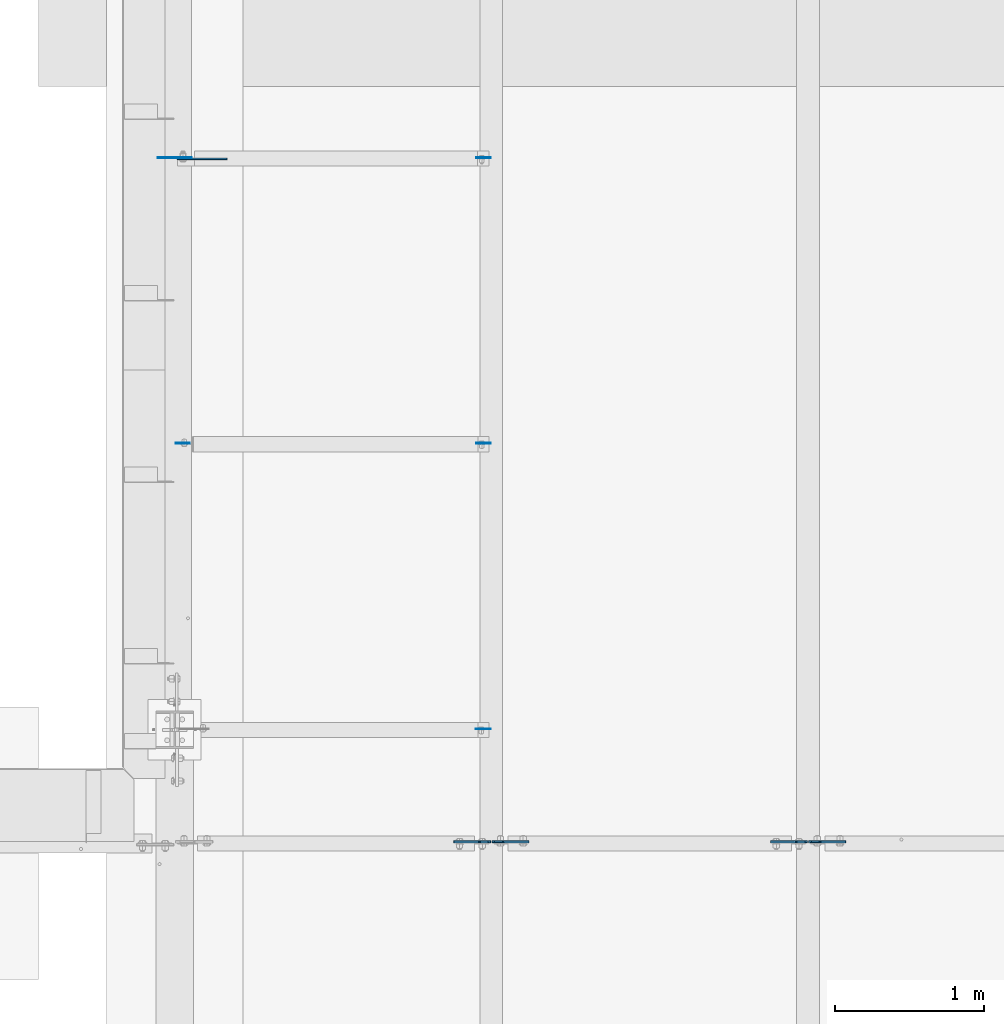
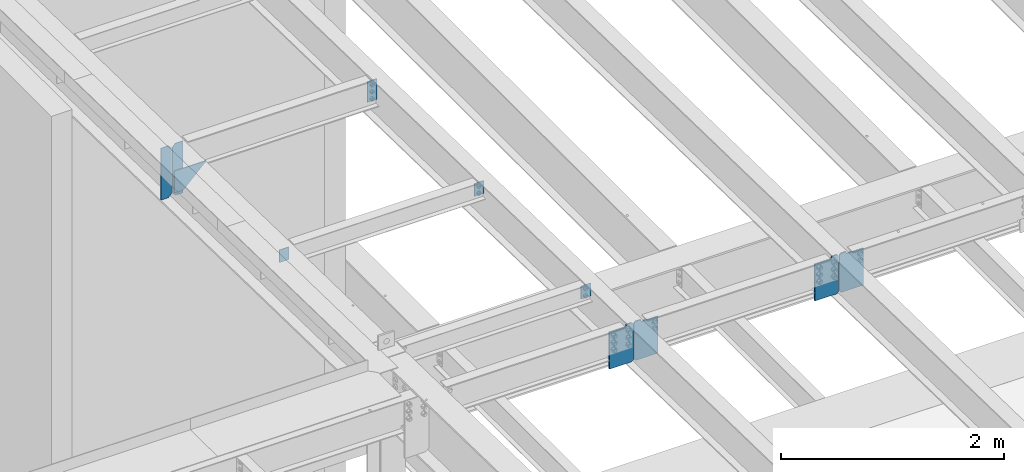
# One storey, part 1497 of 1763: 11 plates, 4 elements without a shape of their own.
"""IFC2X3 building model written with IfcOpenShell, lengths in millimetres."""

from ifc_helpers import new_model, si_unit, frame, origin_with_axes, place, context, subcontext, project, spatial, faceted_brep, material, type_object, element, aggregate, save


model = new_model("IFC2X3")

# Units and contexts
model_context = context("Model", 3, precision=1e-05, world=origin_with_axes())
body_context = subcontext(model_context, "Body", "Model", "MODEL_VIEW")
ifc_project = project(units=[si_unit("LENGTHUNIT", "METRE", prefix="MILLI"), si_unit("AREAUNIT", "SQUARE_METRE"), si_unit("VOLUMEUNIT", "CUBIC_METRE"), si_unit("MASSUNIT", "GRAM", prefix="KILO"), si_unit("TIMEUNIT", "SECOND"), si_unit("PLANEANGLEUNIT", "RADIAN"), si_unit("SOLIDANGLEUNIT", "STERADIAN"), si_unit("THERMODYNAMICTEMPERATUREUNIT", "DEGREE_CELSIUS"), si_unit("LUMINOUSINTENSITYUNIT", "LUMEN")], contexts=[model_context])

# Site, building, storey
site_placement = place(None, origin_with_axes())
site = spatial("IfcSite", under=ifc_project, at=site_placement, CompositionType="ELEMENT")
building_placement = place(site_placement, origin_with_axes())
building = spatial("IfcBuilding", under=site, at=building_placement, Name="Undefined", CompositionType="ELEMENT")
storey_placement = place(building_placement, origin_with_axes())
storey = spatial("IfcBuildingStorey", under=building, at=storey_placement, Name="Undefined", CompositionType="ELEMENT", Elevation=0.0)

# Assembly, plate
assembly_1_placement = place(storey_placement, origin_with_axes())
assembly_1 = element("IfcElementAssembly", 1, at=assembly_1_placement, inside=storey, Name="BEAM", AssemblyPlace="NOTDEFINED", PredefinedType="RIGID_FRAME")
ifc_material_1 = material(Name="STEEL/A36")
plate_type_1 = type_object("IfcPlateType", PredefinedType="NOTDEFINED")
plate_1_placement = place(assembly_1_placement, frame((-87369.8810236984, 24275.2562500014, 11359.7329638948), z_axis=(1.0, 0.0, 0.0), x_axis=(0.0, 0.0, -1.0)))
plate_1 = element("IfcPlate", 2, at=plate_1_placement, type_object=plate_type_1, material=ifc_material_1, Name="PLATE", context=body_context, shape_type="Brep", body=[
    faceted_brep([(1.81898940354586e-12, -3.17500000000291, 0.0), (0.0, -3.17499999999927, 96.8375015258789), (0.0, 3.17499999999927, 96.8375015258789), (-1.81898940354586e-12, 3.17499999997381, 0.0), (139.699996948242, -3.17499999999927, 96.8375015258789), (139.699996948242, 3.17499999999927, 96.8375015258789), (139.699996948242, -3.17499999999927, 0.0), (139.699996948242, 3.17499999999927, 0.0)], [[[0, 1, 2, 3]], [[1, 4, 5, 2]], [[4, 6, 7, 5]], [[6, 0, 3, 7]], [[5, 7, 3, 2]], [[6, 4, 1, 0]]]),
])

# Assembly, plates
assembly_2_placement = place(storey_placement, origin_with_axes())
assembly_2 = element("IfcElementAssembly", 3, at=assembly_2_placement, inside=storey, Name="BEAM", AssemblyPlace="NOTDEFINED", PredefinedType="RIGID_FRAME")
plate_type_2 = type_object("IfcPlateType", PredefinedType="NOTDEFINED")
plate_2_placement = place(assembly_2_placement, frame((-85253.0631665555, 22357.5562499975, 11418.9151589465), z_axis=(-1.0, 0.0, 0.0), x_axis=(0.0, 0.0, -1.0)))
plate_2 = element("IfcPlate", 4, at=plate_2_placement, type_object=plate_type_2, material=ifc_material_1, Name="PLATE", context=body_context, shape_type="Brep", body=[
    faceted_brep([(1.81898940354586e-12, -3.17500000000291, 0.0), (0.0, -3.17499999999927, 101.599998474121), (0.0, 3.17499999999927, 101.599998474121), (-1.81898940354586e-12, 3.17499999997381, 0.0), (139.699996948242, -3.17499999999927, 101.599998474121), (139.699996948242, 3.17499999999927, 101.599998474121), (139.699996948242, -3.17499999999927, 0.0), (139.699996948242, 3.17499999999927, 0.0)], [[[0, 1, 2, 3]], [[1, 4, 5, 2]], [[4, 6, 7, 5]], [[6, 0, 3, 7]], [[5, 7, 3, 2]], [[6, 4, 1, 0]]]),
])
plate_type_3 = type_object("IfcPlateType", PredefinedType="NOTDEFINED")
plate_3_placement = place(assembly_2_placement, frame((-85253.0631665555, 26193.7500001603, 11332.3553075352), z_axis=(-1.0, 0.0, 0.0), x_axis=(0.0, 0.0, -1.0)))
plate_3 = element("IfcPlate", 5, at=plate_3_placement, type_object=plate_type_3, material=ifc_material_1, Name="PLATE", context=body_context, shape_type="Brep", body=[
    faceted_brep([(1.81898940354586e-12, -3.17500000000291, 0.0), (-2.52839527092874e-10, -3.17500000000001, 98.4250000002357), (4.17785486206412e-08, 3.17500000000001, 98.425000000243), (-1.81898940354586e-12, 3.17499999997381, 0.0), (228.600006103516, -3.17499999999927, 98.4250030517578), (228.600006103516, 3.17499999999927, 98.4250030517578), (228.600006103516, -3.17500000001019, -7.27595761418343e-12), (228.600006103516, 3.17499999999563, -7.27595761418343e-12)], [[[0, 1, 2, 3]], [[1, 4, 5, 2]], [[4, 6, 7, 5]], [[6, 0, 3, 7]], [[5, 7, 3, 2]], [[6, 4, 1, 0]]]),
])
plate_4_placement = place(assembly_2_placement, frame((-85253.0631665555, 24275.256249997, 11378.7829639063), z_axis=(-1.0, 0.0, 0.0), x_axis=(0.0, 0.0, -1.0)))
plate_4 = element("IfcPlate", 6, at=plate_4_placement, type_object=plate_type_3, material=ifc_material_1, Name="PLATE", context=body_context, shape_type="Brep", body=[
    faceted_brep([(1.81898940354586e-12, -3.17500000000291, 0.0), (-2.52839527092874e-10, -3.17500000000001, 98.4250000002357), (4.17785486206412e-08, 3.17500000000001, 98.425000000243), (-1.81898940354586e-12, 3.17499999997381, 0.0), (139.699996948242, -3.17499999999927, 98.4250030517578), (139.699996948242, 3.17499999999927, 98.4250030517578), (139.699996948242, -3.17499999999927, 0.0), (139.699996948242, 3.17499999999927, 0.0)], [[[0, 1, 2, 3]], [[1, 4, 5, 2]], [[4, 6, 7, 5]], [[6, 0, 3, 7]], [[5, 7, 3, 2]], [[6, 4, 1, 0]]]),
])

# Assembly, plate
assembly_3_placement = place(storey_placement, origin_with_axes())
assembly_3 = element("IfcElementAssembly", 7, at=assembly_3_placement, inside=storey, Name="BEAM", AssemblyPlace="NOTDEFINED", PredefinedType="RIGID_FRAME")
plate_type_4 = type_object("IfcPlateType", PredefinedType="NOTDEFINED")
plate_5_placement = place(assembly_3_placement, frame((-87260.0435256352, 26185.8125082553, 10822.8728500576), z_axis=(-0.707106781186552, 0.0, 0.707106781186543), x_axis=(0.707106781186542, 0.0, 0.707106781186553)))
plate_5 = element("IfcPlate", 8, at=plate_5_placement, type_object=plate_type_4, material=ifc_material_1, Name="PLATE", context=body_context, shape_type="Brep", body=[
    faceted_brep([(0.0, -4.76249999999982, 0.0), (-68.6865768438074, -4.76249999999709, 68.6865844732238), (-68.6865768438074, 4.76249999999709, 68.6865844732238), (0.0, 4.76249999999982, 0.0), (98.4964141840537, -4.76250000000073, 235.86958313045), (98.4964141840537, 4.76250000000073, 235.86958313045), (334.365997315792, -4.76250000000073, -4.07453626394272e-10), (334.365997315792, 4.76250000000073, -4.07453626394272e-10)], [[[0, 1, 2, 3]], [[1, 4, 5, 2]], [[4, 6, 7, 5]], [[6, 0, 3, 7]], [[5, 7, 3, 2]], [[6, 4, 1, 0]]]),
])
aggregate(assembly_3, [plate_5])

# Plate
plate_type_5 = type_object("IfcPlateType", PredefinedType="NOTDEFINED")
plate_6_placement = place(assembly_1_placement, frame((-87381.2935236983, 26193.7500002351, 10783.1853500575), z_axis=(0.0, 0.0, 1.0), x_axis=(-1.0, 0.0, 0.0)))
plate_6 = element("IfcPlate", 9, at=plate_6_placement, type_object=plate_type_5, material=ifc_material_1, Name="PLATE", context=body_context, shape_type="Brep", body=[
    faceted_brep([(0.0, -3.17500000000291, 31.75), (0.0, -3.17500000000291, 535.965942382812), (0.0, 3.17500000000291, 535.965942382812), (0.0, 3.17500000000291, 31.75), (31.75, -3.17500000000291, 567.715942382812), (31.75, 3.17500000000291, 567.715942382812), (108.743751525879, -3.17500000000291, 567.715942382812), (108.743751525879, 3.17500000000291, 567.715942382812), (108.743751525879, -3.17500000000291, 0.0), (108.743751525879, 3.17500000000291, 0.0), (31.7499999999036, -3.17499999997381, 9.42916855706244e-11), (31.7499999998854, 3.17500000000291, 9.42916855706244e-11)], [[[0, 1, 2, 3]], [[1, 4, 5, 2]], [[4, 6, 7, 5]], [[6, 8, 9, 7]], [[8, 10, 11, 9]], [[10, 0, 3, 11]], [[5, 7, 9, 11, 3, 2]], [[10, 8, 6, 4, 1, 0]]]),
])

plate_7_placement = place(assembly_1_placement, frame((-87369.5810236984, 26193.750000231, 10783.1853500576), z_axis=(0.0, 0.0, 1.0), x_axis=(1.0, 0.0, 0.0)))
plate_7 = element("IfcPlate", 10, at=plate_7_placement, type_object=plate_type_5, material=ifc_material_1, Name="PLATE", context=body_context, shape_type="Brep", body=[
    faceted_brep([(0.0, -3.17500000000291, 31.75), (0.0, -3.17500000000291, 537.553405761719), (0.0, 3.17500000000291, 537.553405761719), (0.0, 3.17500000000291, 31.75), (31.75, -3.17500000000291, 569.303405761719), (31.75, 3.17500000000291, 569.303405761719), (109.537498474121, -3.17500000000291, 569.303405761719), (109.537498474121, 3.17500000000291, 569.303405761719), (109.537498474121, -3.17500000000291, 0.0), (109.537498474121, 3.17500000000291, 0.0), (31.7499999999036, -3.17499999997381, 9.42916855706244e-11), (31.7499999998854, 3.17500000000291, 9.42916855706244e-11)], [[[0, 1, 2, 3]], [[1, 4, 5, 2]], [[4, 6, 7, 5]], [[6, 8, 9, 7]], [[8, 10, 11, 9]], [[10, 0, 3, 11]], [[5, 7, 9, 11, 3, 2]], [[10, 8, 6, 4, 1, 0]]]),
])

aggregate(assembly_1, [plate_6, plate_7, plate_1])

# Assembly, plates
assembly_4_placement = place(storey_placement, origin_with_axes())
assembly_4 = element("IfcElementAssembly", 11, at=assembly_4_placement, inside=storey, Name="BEAM", AssemblyPlace="NOTDEFINED", PredefinedType="RIGID_FRAME")
ifc_material_2 = material(Name="STEEL/A572-50")
plate_type_6 = type_object("IfcPlateType", PredefinedType="NOTDEFINED")
plate_8_placement = place(assembly_4_placement, frame((-83118.4828094126, 21599.5249999828, 11025.4076650546), z_axis=(0.0, 0.0, 1.0), x_axis=(1.0, 0.0, 0.0)))
plate_8 = element("IfcPlate", 12, at=plate_8_placement, type_object=plate_type_6, material=ifc_material_2, Name="PLATE", context=body_context, shape_type="Brep", body=[
    faceted_brep([(71.9312438964844, -6.34999999999854, 427.853149414062), (71.9312438964844, -6.34999999999854, 415.787802696228), (71.9312438964844, 6.34999999999854, 415.787802696228), (71.9312438964844, 6.34999999999854, 427.853149414062), (72.8979738190683, -6.34999999999854, 410.927723178182), (72.8979738190683, 6.34999999999854, 410.927723178182), (75.6509877195494, -6.34999999999854, 406.807546710028), (75.6509877195494, 6.34999999999854, 406.807546710028), (79.7711641877104, -6.34999999999854, 404.05453280955), (79.7711641877104, 6.34999999999854, 404.05453280955), (84.6312437057495, -6.34999999999854, 403.087802886963), (84.6312437057495, 6.34999999999854, 403.087802886963), (247.649993896484, -6.34999999999854, 403.087802886963), (247.649993896484, 6.34999999999854, 403.087802886963), (0.0, -6.34999999999854, 410.390649795532), (17.4624996185303, -6.34999999999854, 427.853149414062), (17.4624996185303, 6.34999999999854, 427.853149414062), (0.0, 6.34999999999854, 410.390649795532), (0.0, -6.34999999999854, 17.4624996185303), (0.0, 6.34999999999854, 17.4624996185303), (17.4624996185303, -6.34999999999854, 0.0), (17.4624996185303, 6.34999999999854, 0.0), (247.649993896484, -6.34999999999854, 0.0), (247.649993896484, 6.34999999999854, 0.0)], [[[0, 1, 2, 3]], [[4, 5, 2, 1]], [[6, 7, 5, 4]], [[8, 9, 7, 6]], [[10, 11, 9, 8]], [[12, 13, 11, 10]], [[14, 15, 16, 17]], [[18, 14, 17, 19]], [[20, 18, 19, 21]], [[22, 20, 21, 23]], [[8, 6, 4, 1, 0, 15, 14, 18, 20, 22, 12, 10]], [[16, 15, 0, 3]], [[23, 21, 19, 17, 16, 3, 2, 5, 7, 9, 11, 13]], [[22, 23, 13, 12]]]),
])
plate_9_placement = place(assembly_4_placement, frame((-83127.0203094126, 21599.5249999976, 11025.4076650543), z_axis=(0.0, 0.0, 1.0), x_axis=(-1.0, 0.0, 0.0)))
plate_9 = element("IfcPlate", 13, at=plate_9_placement, type_object=plate_type_6, material=ifc_material_2, Name="PLATE", context=body_context, shape_type="Brep", body=[
    faceted_brep([(71.9312438964844, -6.34999999999854, 427.853149414062), (71.9312438964844, -6.34999999999854, 415.787802696228), (71.9312438964844, 6.34999999999854, 415.787802696228), (71.9312438964844, 6.34999999999854, 427.853149414062), (72.8979738190683, -6.34999999999854, 410.927723178182), (72.8979738190683, 6.34999999999854, 410.927723178182), (75.6509877195494, -6.34999999999854, 406.807546710028), (75.6509877195494, 6.34999999999854, 406.807546710028), (79.7711641877104, -6.34999999999854, 404.05453280955), (79.7711641877104, 6.34999999999854, 404.05453280955), (84.6312437057495, -6.34999999999854, 403.087802886963), (84.6312437057495, 6.34999999999854, 403.087802886963), (247.649993896484, -6.34999999999854, 403.087802886963), (247.649993896484, 6.34999999999854, 403.087802886963), (0.0, -6.34999999999854, 410.390649795532), (17.4624996185303, -6.34999999999854, 427.853149414062), (17.4624996185303, 6.34999999999854, 427.853149414062), (0.0, 6.34999999999854, 410.390649795532), (0.0, -6.34999999999854, 17.4624996185303), (0.0, 6.34999999999854, 17.4624996185303), (17.4624996185303, -6.34999999999854, 0.0), (17.4624996185303, 6.34999999999854, 0.0), (247.649993896484, -6.34999999999854, 0.0), (247.649993896484, 6.34999999999854, 0.0)], [[[0, 1, 2, 3]], [[4, 5, 2, 1]], [[6, 7, 5, 4]], [[8, 9, 7, 6]], [[10, 11, 9, 8]], [[12, 13, 11, 10]], [[14, 15, 16, 17]], [[18, 14, 17, 19]], [[20, 18, 19, 21]], [[22, 20, 21, 23]], [[8, 6, 4, 1, 0, 15, 14, 18, 20, 22, 12, 10]], [[16, 15, 0, 3]], [[23, 21, 19, 17, 16, 3, 2, 5, 7, 9, 11, 13]], [[22, 23, 13, 12]]]),
])
aggregate(assembly_4, [plate_8, plate_9])

# Plate
plate_10_placement = place(assembly_2_placement, frame((-85244.8256665555, 21599.5249999828, 11025.4076650546), z_axis=(0.0, 0.0, 1.0), x_axis=(1.0, 0.0, 0.0)))
plate_10 = element("IfcPlate", 14, at=plate_10_placement, type_object=plate_type_6, material=ifc_material_2, Name="PLATE", context=body_context, shape_type="Brep", body=[
    faceted_brep([(71.9312438964844, -6.34999999999854, 427.853149414062), (71.9312438964844, -6.34999999999854, 415.787802696228), (71.9312438964844, 6.34999999999854, 415.787802696228), (71.9312438964844, 6.34999999999854, 427.853149414062), (72.8979738190683, -6.34999999999854, 410.927723178182), (72.8979738190683, 6.34999999999854, 410.927723178182), (75.6509877195494, -6.34999999999854, 406.807546710028), (75.6509877195494, 6.34999999999854, 406.807546710028), (79.7711641877104, -6.34999999999854, 404.05453280955), (79.7711641877104, 6.34999999999854, 404.05453280955), (84.6312437057495, -6.34999999999854, 403.087802886963), (84.6312437057495, 6.34999999999854, 403.087802886963), (247.649993896484, -6.34999999999854, 403.087802886963), (247.649993896484, 6.34999999999854, 403.087802886963), (0.0, -6.34999999999854, 410.390649795532), (17.4624996185303, -6.34999999999854, 427.853149414062), (17.4624996185303, 6.34999999999854, 427.853149414062), (0.0, 6.34999999999854, 410.390649795532), (0.0, -6.34999999999854, 17.4624996185303), (0.0, 6.34999999999854, 17.4624996185303), (17.4624996185303, -6.34999999999854, 0.0), (17.4624996185303, 6.34999999999854, 0.0), (247.649993896484, -6.34999999999854, 0.0), (247.649993896484, 6.34999999999854, 0.0)], [[[0, 1, 2, 3]], [[4, 5, 2, 1]], [[6, 7, 5, 4]], [[8, 9, 7, 6]], [[10, 11, 9, 8]], [[12, 13, 11, 10]], [[14, 15, 16, 17]], [[18, 14, 17, 19]], [[20, 18, 19, 21]], [[22, 20, 21, 23]], [[8, 6, 4, 1, 0, 15, 14, 18, 20, 22, 12, 10]], [[16, 15, 0, 3]], [[23, 21, 19, 17, 16, 3, 2, 5, 7, 9, 11, 13]], [[22, 23, 13, 12]]]),
])

plate_11_placement = place(assembly_2_placement, frame((-85253.3631665555, 21599.5249999828, 11025.4076650546), z_axis=(0.0, 0.0, 1.0), x_axis=(-1.0, 0.0, 0.0)))
plate_11 = element("IfcPlate", 15, at=plate_11_placement, type_object=plate_type_6, material=ifc_material_2, Name="PLATE", context=body_context, shape_type="Brep", body=[
    faceted_brep([(71.9312438964844, -6.34999999999854, 427.853149414062), (71.9312438964844, -6.34999999999854, 415.787802696228), (71.9312438964844, 6.34999999999854, 415.787802696228), (71.9312438964844, 6.34999999999854, 427.853149414062), (72.8979738190683, -6.34999999999854, 410.927723178182), (72.8979738190683, 6.34999999999854, 410.927723178182), (75.6509877195494, -6.34999999999854, 406.807546710028), (75.6509877195494, 6.34999999999854, 406.807546710028), (79.7711641877104, -6.34999999999854, 404.05453280955), (79.7711641877104, 6.34999999999854, 404.05453280955), (84.6312437057495, -6.34999999999854, 403.087802886963), (84.6312437057495, 6.34999999999854, 403.087802886963), (247.649993896484, -6.34999999999854, 403.087802886963), (247.649993896484, 6.34999999999854, 403.087802886963), (0.0, -6.34999999999854, 410.390649795532), (17.4624996185303, -6.34999999999854, 427.853149414062), (17.4624996185303, 6.34999999999854, 427.853149414062), (0.0, 6.34999999999854, 410.390649795532), (0.0, -6.34999999999854, 17.4624996185303), (0.0, 6.34999999999854, 17.4624996185303), (17.4624996185303, -6.34999999999854, 0.0), (17.4624996185303, 6.34999999999854, 0.0), (247.649993896484, -6.34999999999854, 0.0), (247.649993896484, 6.34999999999854, 0.0)], [[[0, 1, 2, 3]], [[4, 5, 2, 1]], [[6, 7, 5, 4]], [[8, 9, 7, 6]], [[10, 11, 9, 8]], [[12, 13, 11, 10]], [[14, 15, 16, 17]], [[18, 14, 17, 19]], [[20, 18, 19, 21]], [[22, 20, 21, 23]], [[8, 6, 4, 1, 0, 15, 14, 18, 20, 22, 12, 10]], [[16, 15, 0, 3]], [[23, 21, 19, 17, 16, 3, 2, 5, 7, 9, 11, 13]], [[22, 23, 13, 12]]]),
])

aggregate(assembly_2, [plate_10, plate_11, plate_2, plate_3, plate_4])

save(model, "model.ifc")
